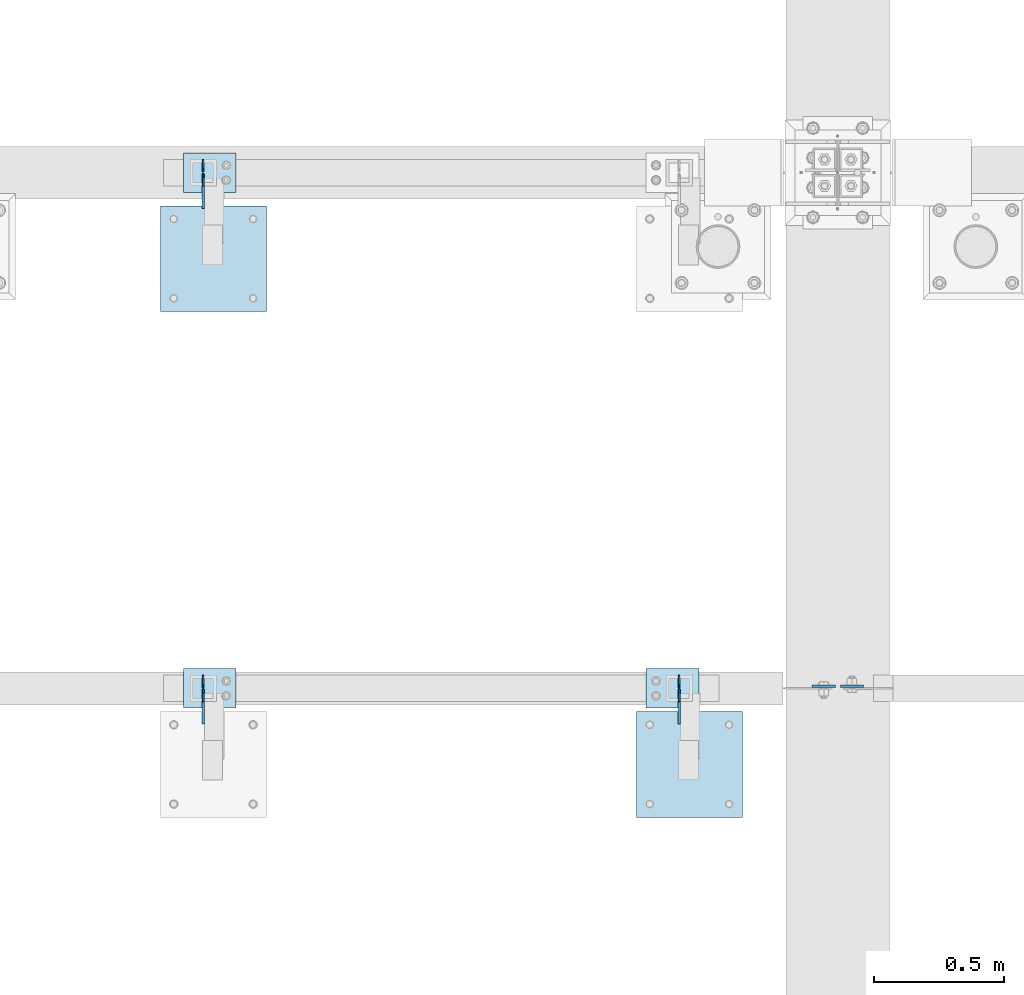
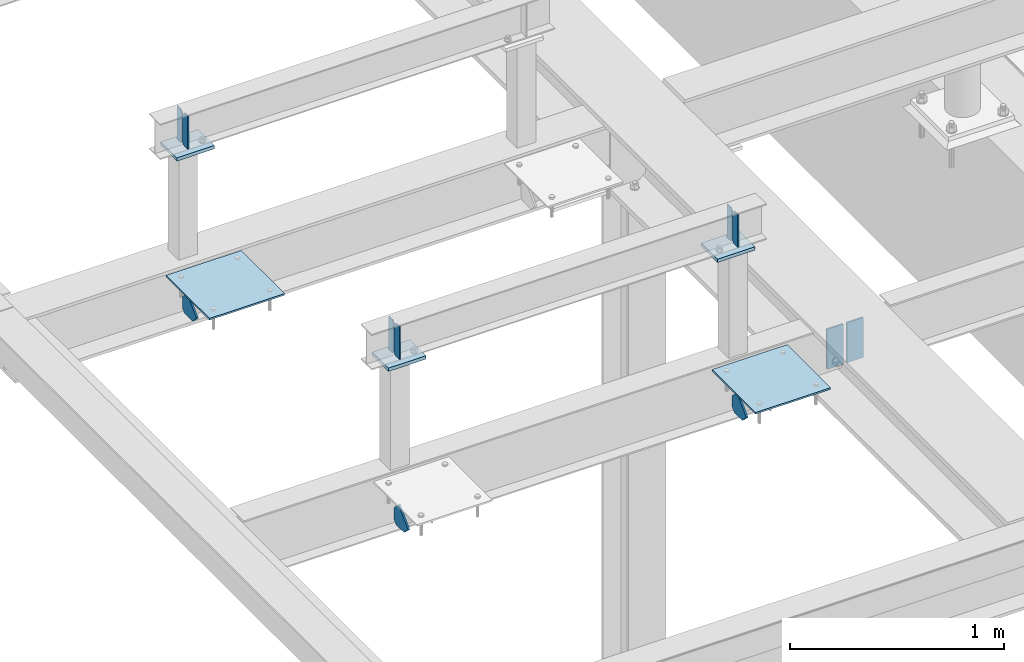
# One storey, part 3011 of 3843: 16 plates, 11 elements without a shape of their own.
"""IFC2X3 building model written with IfcOpenShell, lengths in millimetres."""

from ifc_helpers import new_model, si_unit, frame, origin_with_axes, place, context, subcontext, project, spatial, faceted_brep, material, type_object, element, aggregate, save


model = new_model("IFC2X3")

# Units and contexts
model_context = context("Model", 3, precision=1e-05, world=origin_with_axes())
body_context = subcontext(model_context, "Body", "Model", "MODEL_VIEW")
ifc_project = project(units=[si_unit("LENGTHUNIT", "METRE", prefix="MILLI"), si_unit("AREAUNIT", "SQUARE_METRE"), si_unit("VOLUMEUNIT", "CUBIC_METRE"), si_unit("MASSUNIT", "GRAM", prefix="KILO"), si_unit("TIMEUNIT", "SECOND"), si_unit("PLANEANGLEUNIT", "RADIAN"), si_unit("SOLIDANGLEUNIT", "STERADIAN"), si_unit("THERMODYNAMICTEMPERATUREUNIT", "DEGREE_CELSIUS"), si_unit("LUMINOUSINTENSITYUNIT", "LUMEN")], contexts=[model_context])

# Site, building, storey
site_placement = place(None, origin_with_axes())
site = spatial("IfcSite", under=ifc_project, at=site_placement, CompositionType="ELEMENT")
building_placement = place(site_placement, origin_with_axes())
building = spatial("IfcBuilding", under=site, at=building_placement, Name="Undefined", CompositionType="ELEMENT")
storey_placement = place(building_placement, origin_with_axes())
storey = spatial("IfcBuildingStorey", under=building, at=storey_placement, Name="Undefined", CompositionType="ELEMENT", Elevation=0.0)

# Assembly, plates
assembly_1_placement = place(storey_placement, origin_with_axes())
assembly_1 = element("IfcElementAssembly", 1, at=assembly_1_placement, inside=storey, Name="BEAM", AssemblyPlace="NOTDEFINED", PredefinedType="RIGID_FRAME")
ifc_material = material(Name="STEEL/A572-50")
plate_type_1 = type_object("IfcPlateType", PredefinedType="NOTDEFINED")
plate_1_placement = place(assembly_1_placement, frame((36585.525, 13025.4375, 34747.2), z_axis=(1.0, 0.0, 0.0), x_axis=(0.0, 0.0, -1.0)))
plate_1 = element("IfcPlate", 2, at=plate_1_placement, type_object=plate_type_1, material=ifc_material, Name="PLATE", context=body_context, shape_type="Brep", body=[
    faceted_brep([(0.0, -4.76249999999709, 0.0), (0.0, -4.76249999999709, 88.9000015258789), (0.0, 4.76249999999709, 88.9000015258789), (0.0, 4.76249999999709, 0.0), (228.600006102781, -4.7625000004191, 88.9000015257589), (228.600006102781, 4.76249999954598, 88.9000015257443), (228.600006103079, -4.7625000004482, 7.27595761418343e-12), (228.600006103079, 4.76249999954598, -7.27595761418343e-12)], [[[0, 1, 2, 3]], [[1, 4, 5, 2]], [[4, 6, 7, 5]], [[6, 0, 3, 7]], [[5, 7, 3, 2]], [[6, 4, 1, 0]]]),
])
plate_2_placement = place(assembly_1_placement, frame((36566.475, 13025.4375, 34747.2), z_axis=(-1.0, 0.0, 0.0), x_axis=(0.0, 0.0, -1.0)))
plate_2 = element("IfcPlate", 3, at=plate_2_placement, type_object=plate_type_1, material=ifc_material, Name="PLATE", context=body_context, shape_type="Brep", body=[
    faceted_brep([(0.0, -4.76249999999709, 0.0), (0.0, -4.76249999999709, 88.9000015258789), (0.0, 4.76249999999709, 88.9000015258789), (0.0, 4.76249999999709, 0.0), (228.600006102781, -4.7625000004191, 88.9000015257589), (228.600006102781, 4.76249999954598, 88.9000015257443), (228.600006103079, -4.7625000004482, 7.27595761418343e-12), (228.600006103079, 4.76249999954598, -7.27595761418343e-12)], [[[0, 1, 2, 3]], [[1, 4, 5, 2]], [[4, 6, 7, 5]], [[6, 0, 3, 7]], [[5, 7, 3, 2]], [[6, 4, 1, 0]]]),
])
aggregate(assembly_1, [plate_1, plate_2])

assembly_2_placement = place(storey_placement, origin_with_axes())
assembly_2 = element("IfcElementAssembly", 4, at=assembly_2_placement, inside=storey, Name="BEAM", AssemblyPlace="NOTDEFINED", PredefinedType="RIGID_FRAME")
plate_type_2 = type_object("IfcPlateType", PredefinedType="NOTDEFINED")
plate_3_placement = place(assembly_2_placement, frame((34137.6, 12966.7, 35615.5624969482), z_axis=(0.0, 0.0, -1.0), x_axis=(0.0, 1.0, 0.0)))
plate_3 = element("IfcPlate", 5, at=plate_3_placement, type_object=plate_type_2, material=ifc_material, Name="STIFFENER", context=body_context, shape_type="Brep", body=[
    faceted_brep([(0.0, -3.17499999999927, 0.0), (0.0, -3.17500000000291, 187.324999999997), (0.0, 3.17500000000291, 187.324999999997), (0.0, 3.17499999999927, 0.0), (34.9250001907349, -3.17500000000291, 187.324999999997), (34.9250001907349, 3.17500000000291, 187.324999999997), (47.625, -3.17500000000291, 174.625000190732), (47.625, 3.17500000000291, 174.625000190732), (47.625, -3.17499999999927, 12.6999998092651), (47.625, 3.17499999999927, 12.6999998092651), (34.9250001907349, -3.17499999999927, 0.0), (34.9250001907349, 3.17499999999927, 0.0)], [[[0, 1, 2, 3]], [[1, 4, 5, 2]], [[4, 6, 7, 5]], [[6, 8, 9, 7]], [[8, 10, 11, 9]], [[10, 0, 3, 11]], [[5, 7, 9, 11, 3, 2]], [[10, 8, 6, 4, 1, 0]]]),
])
plate_4_placement = place(assembly_2_placement, frame((34137.6, 13068.3, 35615.5624969482), z_axis=(0.0, 0.0, -1.0), x_axis=(0.0, -1.0, 0.0)))
plate_4 = element("IfcPlate", 6, at=plate_4_placement, type_object=plate_type_2, material=ifc_material, Name="STIFFENER", context=body_context, shape_type="Brep", body=[
    faceted_brep([(0.0, -3.17499999999927, 0.0), (0.0, -3.17500000000291, 187.324999999997), (0.0, 3.17500000000291, 187.324999999997), (0.0, 3.17499999999927, 0.0), (34.9250001907349, -3.17500000000291, 187.324999999997), (34.9250001907349, 3.17500000000291, 187.324999999997), (47.625, -3.17500000000291, 174.625000190732), (47.625, 3.17500000000291, 174.625000190732), (47.625, -3.17499999999927, 12.6999998092651), (47.625, 3.17499999999927, 12.6999998092651), (34.9250001907349, -3.17499999999927, 0.0), (34.9250001907349, 3.17499999999927, 0.0)], [[[0, 1, 2, 3]], [[1, 4, 5, 2]], [[4, 6, 7, 5]], [[6, 8, 9, 7]], [[8, 10, 11, 9]], [[10, 0, 3, 11]], [[5, 7, 9, 11, 3, 2]], [[10, 8, 6, 4, 1, 0]]]),
])
plate_5_placement = place(assembly_2_placement, frame((35966.4, 13068.3, 35615.5624969482), z_axis=(0.0, 0.0, -1.0), x_axis=(0.0, -1.0, 0.0)))
plate_5 = element("IfcPlate", 7, at=plate_5_placement, type_object=plate_type_2, material=ifc_material, Name="STIFFENER", context=body_context, shape_type="Brep", body=[
    faceted_brep([(0.0, -3.17499999999927, 0.0), (0.0, -3.17500000000291, 187.324999999997), (0.0, 3.17500000000291, 187.324999999997), (0.0, 3.17499999999927, 0.0), (34.9250001907349, -3.17500000000291, 187.324999999997), (34.9250001907349, 3.17500000000291, 187.324999999997), (47.625, -3.17500000000291, 174.625000190732), (47.625, 3.17500000000291, 174.625000190732), (47.625, -3.17499999999927, 12.6999998092651), (47.625, 3.17499999999927, 12.6999998092651), (34.9250001907349, -3.17499999999927, 0.0), (34.9250001907349, 3.17499999999927, 0.0)], [[[0, 1, 2, 3]], [[1, 4, 5, 2]], [[4, 6, 7, 5]], [[6, 8, 9, 7]], [[8, 10, 11, 9]], [[10, 0, 3, 11]], [[5, 7, 9, 11, 3, 2]], [[10, 8, 6, 4, 1, 0]]]),
])
plate_6_placement = place(assembly_2_placement, frame((35966.4, 12966.7, 35615.5624969482), z_axis=(0.0, 0.0, -1.0), x_axis=(0.0, 1.0, 0.0)))
plate_6 = element("IfcPlate", 8, at=plate_6_placement, type_object=plate_type_2, material=ifc_material, Name="STIFFENER", context=body_context, shape_type="Brep", body=[
    faceted_brep([(0.0, -3.17499999999927, 0.0), (0.0, -3.17500000000291, 187.324999999997), (0.0, 3.17500000000291, 187.324999999997), (0.0, 3.17499999999927, 0.0), (34.9250001907349, -3.17500000000291, 187.324999999997), (34.9250001907349, 3.17500000000291, 187.324999999997), (47.625, -3.17500000000291, 174.625000190732), (47.625, 3.17500000000291, 174.625000190732), (47.625, -3.17499999999927, 12.6999998092651), (47.625, 3.17499999999927, 12.6999998092651), (34.9250001907349, -3.17499999999927, 0.0), (34.9250001907349, 3.17499999999927, 0.0)], [[[0, 1, 2, 3]], [[1, 4, 5, 2]], [[4, 6, 7, 5]], [[6, 8, 9, 7]], [[8, 10, 11, 9]], [[10, 0, 3, 11]], [[5, 7, 9, 11, 3, 2]], [[10, 8, 6, 4, 1, 0]]]),
])
aggregate(assembly_2, [plate_3, plate_4, plate_5, plate_6])

assembly_3_placement = place(storey_placement, origin_with_axes())
assembly_3 = element("IfcElementAssembly", 9, at=assembly_3_placement, inside=storey, Name="BEAM", AssemblyPlace="NOTDEFINED", PredefinedType="RIGID_FRAME")
plate_7_placement = place(assembly_3_placement, frame((34137.6, 14947.9, 35615.5624969482), z_axis=(0.0, 0.0, -1.0), x_axis=(0.0, 1.0, 0.0)))
plate_7 = element("IfcPlate", 10, at=plate_7_placement, type_object=plate_type_2, material=ifc_material, Name="STIFFENER", context=body_context, shape_type="Brep", body=[
    faceted_brep([(0.0, -3.17499999999927, 0.0), (0.0, -3.17500000000291, 187.324999999997), (0.0, 3.17500000000291, 187.324999999997), (0.0, 3.17499999999927, 0.0), (34.9250001907349, -3.17500000000291, 187.324999999997), (34.9250001907349, 3.17500000000291, 187.324999999997), (47.625, -3.17500000000291, 174.625000190732), (47.625, 3.17500000000291, 174.625000190732), (47.625, -3.17499999999927, 12.6999998092651), (47.625, 3.17499999999927, 12.6999998092651), (34.9250001907349, -3.17499999999927, 0.0), (34.9250001907349, 3.17499999999927, 0.0)], [[[0, 1, 2, 3]], [[1, 4, 5, 2]], [[4, 6, 7, 5]], [[6, 8, 9, 7]], [[8, 10, 11, 9]], [[10, 0, 3, 11]], [[5, 7, 9, 11, 3, 2]], [[10, 8, 6, 4, 1, 0]]]),
])
plate_8_placement = place(assembly_3_placement, frame((34137.6, 15049.5, 35615.5624969482), z_axis=(0.0, 0.0, -1.0), x_axis=(0.0, -1.0, 0.0)))
plate_8 = element("IfcPlate", 11, at=plate_8_placement, type_object=plate_type_2, material=ifc_material, Name="STIFFENER", context=body_context, shape_type="Brep", body=[
    faceted_brep([(0.0, -3.17499999999927, 0.0), (0.0, -3.17500000000291, 187.324999999997), (0.0, 3.17500000000291, 187.324999999997), (0.0, 3.17499999999927, 0.0), (34.9250001907349, -3.17500000000291, 187.324999999997), (34.9250001907349, 3.17500000000291, 187.324999999997), (47.625, -3.17500000000291, 174.625000190732), (47.625, 3.17500000000291, 174.625000190732), (47.625, -3.17499999999927, 12.6999998092651), (47.625, 3.17499999999927, 12.6999998092651), (34.9250001907349, -3.17499999999927, 0.0), (34.9250001907349, 3.17499999999927, 0.0)], [[[0, 1, 2, 3]], [[1, 4, 5, 2]], [[4, 6, 7, 5]], [[6, 8, 9, 7]], [[8, 10, 11, 9]], [[10, 0, 3, 11]], [[5, 7, 9, 11, 3, 2]], [[10, 8, 6, 4, 1, 0]]]),
])
aggregate(assembly_3, [plate_7, plate_8])

# Assembly, plate
assembly_4_placement = place(storey_placement, origin_with_axes())
assembly_4 = element("IfcElementAssembly", 12, at=assembly_4_placement, inside=storey, Name="PLATE", AssemblyPlace="NOTDEFINED", PredefinedType="RIGID_FRAME")
plate_type_3 = type_object("IfcPlateType", PredefinedType="NOTDEFINED")
plate_9_placement = place(assembly_4_placement, frame((34137.6, 13014.325, 34469.3875), z_axis=(0.0, -1.0, 0.0), x_axis=(0.0, 0.0, 1.0)))
plate_9 = element("IfcPlate", 13, at=plate_9_placement, type_object=plate_type_3, material=ifc_material, Name="PLATE", context=body_context, shape_type="Brep", body=[
    faceted_brep([(0.0, -4.76249999999709, 19.0499992370605), (0.0, -4.76249999999709, 94.5650612206882), (0.0, 4.76249999999709, 94.5650612206882), (0.0, 4.76249999999709, 19.0499992370605), (38.5980122320107, -4.76249999999709, 133.163073452699), (38.5980122320107, 4.76249999999709, 133.163073452699), (128.400573442581, -4.76249999999709, 43.3605122421359), (128.400573442581, 4.76249999999709, 43.3605122421359), (85.0400612004451, -4.76249999999709, 0.0), (85.0400612004451, 4.76249999999709, 0.0), (19.0499992370605, -4.76249999999709, 0.0), (19.0499992370605, 4.76249999999709, 0.0)], [[[0, 1, 2, 3]], [[1, 4, 5, 2]], [[4, 6, 7, 5]], [[6, 8, 9, 7]], [[8, 10, 11, 9]], [[10, 0, 3, 11]], [[5, 7, 9, 11, 3, 2]], [[10, 8, 6, 4, 1, 0]]]),
])
aggregate(assembly_4, [plate_9])

assembly_5_placement = place(storey_placement, origin_with_axes())
assembly_5 = element("IfcElementAssembly", 14, at=assembly_5_placement, inside=storey, Name="PLATE", AssemblyPlace="NOTDEFINED", PredefinedType="RIGID_FRAME")
plate_10_placement = place(assembly_5_placement, frame((35966.4, 13014.325, 34469.3875), z_axis=(0.0, -1.0, 0.0), x_axis=(0.0, 0.0, 1.0)))
plate_10 = element("IfcPlate", 15, at=plate_10_placement, type_object=plate_type_3, material=ifc_material, Name="PLATE", context=body_context, shape_type="Brep", body=[
    faceted_brep([(0.0, -4.76249999999709, 19.0499992370605), (0.0, -4.76249999999709, 94.5650612206882), (0.0, 4.76249999999709, 94.5650612206882), (0.0, 4.76249999999709, 19.0499992370605), (38.5980122320107, -4.76249999999709, 133.163073452699), (38.5980122320107, 4.76249999999709, 133.163073452699), (128.400573442581, -4.76249999999709, 43.3605122421359), (128.400573442581, 4.76249999999709, 43.3605122421359), (85.0400612004451, -4.76249999999709, 0.0), (85.0400612004451, 4.76249999999709, 0.0), (19.0499992370605, -4.76249999999709, 0.0), (19.0499992370605, 4.76249999999709, 0.0)], [[[0, 1, 2, 3]], [[1, 4, 5, 2]], [[4, 6, 7, 5]], [[6, 8, 9, 7]], [[8, 10, 11, 9]], [[10, 0, 3, 11]], [[5, 7, 9, 11, 3, 2]], [[10, 8, 6, 4, 1, 0]]]),
])
aggregate(assembly_5, [plate_10])

assembly_6_placement = place(storey_placement, origin_with_axes())
assembly_6 = element("IfcElementAssembly", 16, at=assembly_6_placement, inside=storey, Name="PLATE", AssemblyPlace="NOTDEFINED", PredefinedType="RIGID_FRAME")
plate_11_placement = place(assembly_6_placement, frame((34137.6, 14993.9375, 34475.7375), z_axis=(0.0, -1.0, 0.0), x_axis=(0.0, 0.0, 1.0)))
plate_11 = element("IfcPlate", 17, at=plate_11_placement, type_object=plate_type_3, material=ifc_material, Name="PLATE", context=body_context, shape_type="Brep", body=[
    faceted_brep([(0.0, -4.76249999999709, 19.0499992370605), (0.0, -4.76249999999709, 94.5650612206882), (0.0, 4.76249999999709, 94.5650612206882), (0.0, 4.76249999999709, 19.0499992370605), (38.5980122320107, -4.76249999999709, 133.163073452699), (38.5980122320107, 4.76249999999709, 133.163073452699), (128.400573442581, -4.76249999999709, 43.3605122421359), (128.400573442581, 4.76249999999709, 43.3605122421359), (85.0400612004451, -4.76249999999709, 0.0), (85.0400612004451, 4.76249999999709, 0.0), (19.0499992370605, -4.76249999999709, 0.0), (19.0499992370605, 4.76249999999709, 0.0)], [[[0, 1, 2, 3]], [[1, 4, 5, 2]], [[4, 6, 7, 5]], [[6, 8, 9, 7]], [[8, 10, 11, 9]], [[10, 0, 3, 11]], [[5, 7, 9, 11, 3, 2]], [[10, 8, 6, 4, 1, 0]]]),
])
aggregate(assembly_6, [plate_11])

assembly_7_placement = place(storey_placement, origin_with_axes())
assembly_7 = element("IfcElementAssembly", 18, at=assembly_7_placement, inside=storey, Name="PLATE", AssemblyPlace="NOTDEFINED", PredefinedType="RIGID_FRAME")
plate_type_4 = type_object("IfcPlateType", PredefinedType="NOTDEFINED")
plate_12_placement = place(assembly_7_placement, frame((35802.8875, 12928.5065367161, 34805.9375), z_axis=(1.0, 0.0, 0.0), x_axis=(0.0, -1.0, 0.0)))
plate_12 = element("IfcPlate", 19, at=plate_12_placement, type_object=plate_type_4, material=ifc_material, Name="PLATE", context=body_context, shape_type="Brep", body=[
    faceted_brep([(0.0, -4.76249999999709, 0.0), (-7.27595761418343e-12, -4.76249999999709, 406.400000000009), (-7.27595761418343e-12, 4.76249999999709, 406.400000000009), (0.0, 4.76249999999709, 0.0), (406.399999999991, -4.76249999999709, 406.400000000009), (406.399999999991, 4.76249999999709, 406.400000000009), (406.399999999998, -4.76249999999709, 7.27595761418343e-12), (406.399999999998, 4.76249999999709, 7.27595761418343e-12)], [[[0, 1, 2, 3]], [[1, 4, 5, 2]], [[4, 6, 7, 5]], [[6, 0, 3, 7]], [[5, 7, 3, 2]], [[6, 4, 1, 0]]]),
])
aggregate(assembly_7, [plate_12])

assembly_8_placement = place(storey_placement, origin_with_axes())
assembly_8 = element("IfcElementAssembly", 20, at=assembly_8_placement, inside=storey, Name="PLATE", AssemblyPlace="NOTDEFINED", PredefinedType="RIGID_FRAME")
plate_13_placement = place(assembly_8_placement, frame((33974.0875, 14871.7, 34805.9375), z_axis=(1.0, 0.0, 0.0), x_axis=(0.0, -1.0, 0.0)))
plate_13 = element("IfcPlate", 21, at=plate_13_placement, type_object=plate_type_4, material=ifc_material, Name="PLATE", context=body_context, shape_type="Brep", body=[
    faceted_brep([(0.0, -4.76249999999709, 0.0), (-7.27595761418343e-12, -4.76249999999709, 406.400000000009), (-7.27595761418343e-12, 4.76249999999709, 406.400000000009), (0.0, 4.76249999999709, 0.0), (406.399999999991, -4.76249999999709, 406.400000000009), (406.399999999991, 4.76249999999709, 406.400000000009), (406.399999999998, -4.76249999999709, 7.27595761418343e-12), (406.399999999998, 4.76249999999709, 7.27595761418343e-12)], [[[0, 1, 2, 3]], [[1, 4, 5, 2]], [[4, 6, 7, 5]], [[6, 0, 3, 7]], [[5, 7, 3, 2]], [[6, 4, 1, 0]]]),
])
aggregate(assembly_8, [plate_13])

assembly_9_placement = place(storey_placement, origin_with_axes())
assembly_9 = element("IfcElementAssembly", 22, at=assembly_9_placement, inside=storey, Name="POST", AssemblyPlace="NOTDEFINED", PredefinedType="RIGID_FRAME")
plate_type_5 = type_object("IfcPlateType", PredefinedType="NOTDEFINED")
plate_14_placement = place(assembly_9_placement, frame((34264.6, 13093.7, 35410.7749969482), z_axis=(-1.0, 0.0, 0.0), x_axis=(0.0, -1.0, 0.0)))
plate_14 = element("IfcPlate", 23, at=plate_14_placement, type_object=plate_type_5, material=ifc_material, Name="PLATE", context=body_context, shape_type="Brep", body=[
    faceted_brep([(0.0, -9.52500000000146, 0.0), (0.0, -9.52500000000146, 203.200000000004), (0.0, 9.52500000000146, 203.200000000004), (0.0, 9.52500000000146, 0.0), (152.400000000001, -9.52500000000146, 203.200000000004), (152.400000000001, 9.52500000000146, 203.200000000004), (152.400000000001, -9.52500000000146, 0.0), (152.400000000001, 9.52500000000146, 0.0)], [[[0, 1, 2, 3]], [[1, 4, 5, 2]], [[4, 6, 7, 5]], [[6, 0, 3, 7]], [[5, 7, 3, 2]], [[6, 4, 1, 0]]]),
])
aggregate(assembly_9, [plate_14])

assembly_10_placement = place(storey_placement, origin_with_axes())
assembly_10 = element("IfcElementAssembly", 24, at=assembly_10_placement, inside=storey, Name="POST", AssemblyPlace="NOTDEFINED", PredefinedType="RIGID_FRAME")
plate_15_placement = place(assembly_10_placement, frame((36042.6, 13093.7, 35410.7749969482), z_axis=(-1.0, 0.0, 0.0), x_axis=(0.0, -1.0, 0.0)))
plate_15 = element("IfcPlate", 25, at=plate_15_placement, type_object=plate_type_5, material=ifc_material, Name="PLATE", context=body_context, shape_type="Brep", body=[
    faceted_brep([(0.0, -9.52500000000146, 0.0), (0.0, -9.52500000000146, 203.200000000004), (0.0, 9.52500000000146, 203.200000000004), (0.0, 9.52500000000146, 0.0), (152.400000000001, -9.52500000000146, 203.200000000004), (152.400000000001, 9.52500000000146, 203.200000000004), (152.400000000001, -9.52500000000146, 0.0), (152.400000000001, 9.52500000000146, 0.0)], [[[0, 1, 2, 3]], [[1, 4, 5, 2]], [[4, 6, 7, 5]], [[6, 0, 3, 7]], [[5, 7, 3, 2]], [[6, 4, 1, 0]]]),
])
aggregate(assembly_10, [plate_15])

assembly_11_placement = place(storey_placement, origin_with_axes())
assembly_11 = element("IfcElementAssembly", 26, at=assembly_11_placement, inside=storey, Name="POST", AssemblyPlace="NOTDEFINED", PredefinedType="RIGID_FRAME")
plate_16_placement = place(assembly_11_placement, frame((34264.6, 15074.9, 35410.7749969482), z_axis=(-1.0, 0.0, 0.0), x_axis=(0.0, -1.0, 0.0)))
plate_16 = element("IfcPlate", 27, at=plate_16_placement, type_object=plate_type_5, material=ifc_material, Name="PLATE", context=body_context, shape_type="Brep", body=[
    faceted_brep([(0.0, -9.52500000000146, 0.0), (0.0, -9.52500000000146, 203.200000000004), (0.0, 9.52500000000146, 203.200000000004), (0.0, 9.52500000000146, 0.0), (152.400000000001, -9.52500000000146, 203.200000000004), (152.400000000001, 9.52500000000146, 203.200000000004), (152.400000000001, -9.52500000000146, 0.0), (152.400000000001, 9.52500000000146, 0.0)], [[[0, 1, 2, 3]], [[1, 4, 5, 2]], [[4, 6, 7, 5]], [[6, 0, 3, 7]], [[5, 7, 3, 2]], [[6, 4, 1, 0]]]),
])
aggregate(assembly_11, [plate_16])

save(model, "model.ifc")
